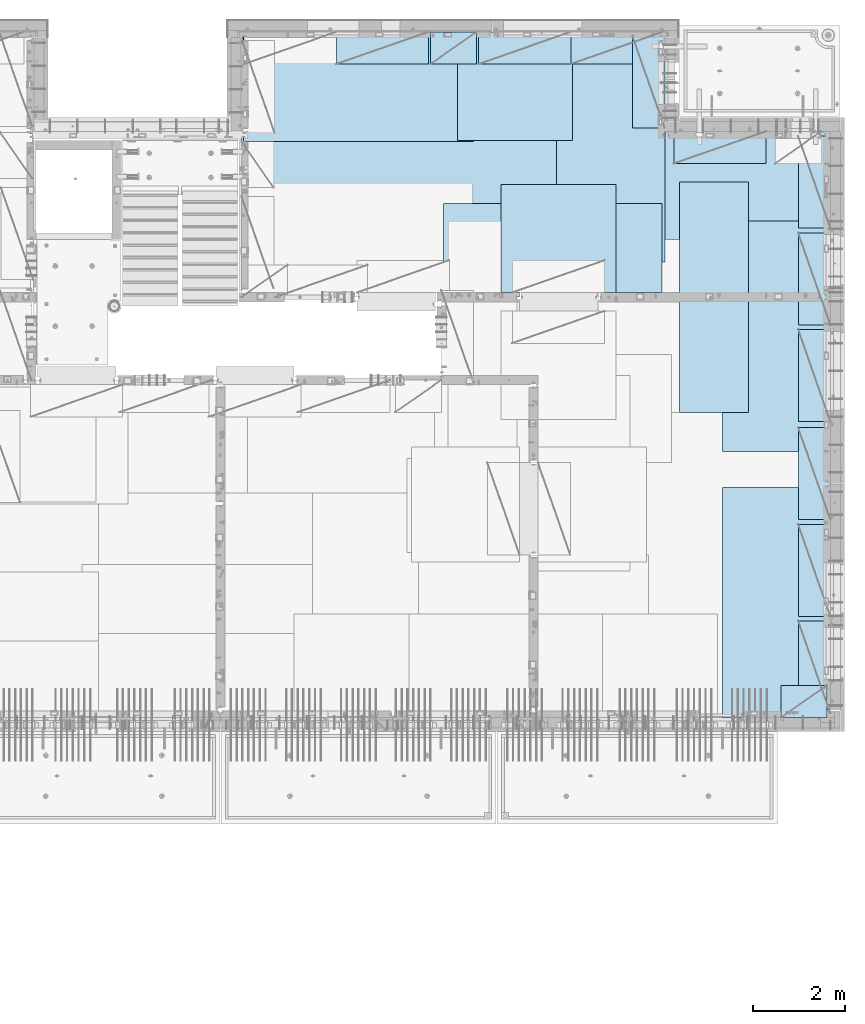
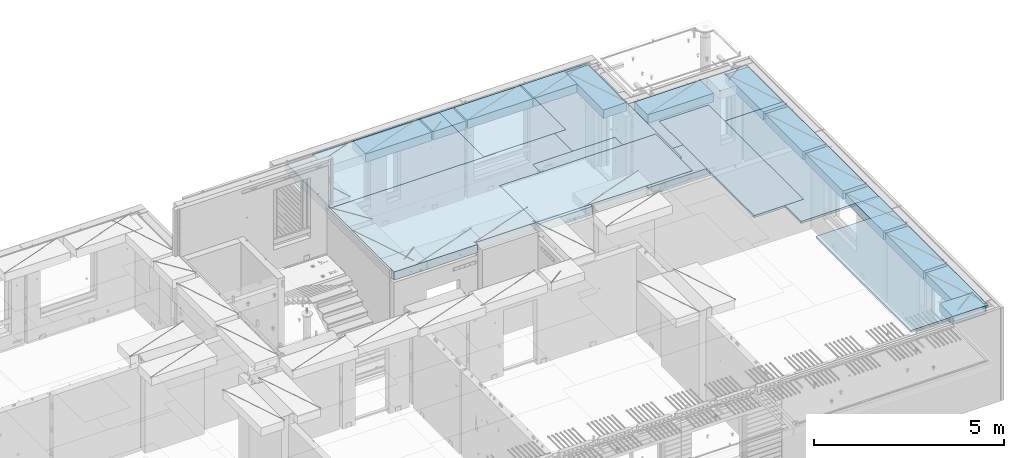
# One storey, part 202 of 341: 22 plates, 1 slab, 22 elements without a shape of their own.
"""IFC2X3 building model written with IfcOpenShell, lengths in millimetres."""

from ifc_helpers import new_model, si_unit, frame, origin_with_axes, place, context, subcontext, project, spatial, faceted_brep, material, type_object, element, aggregate, save


model = new_model("IFC2X3")

# Units and contexts
model_context = context("Model", 3, precision=1e-05, world=origin_with_axes())
body_context = subcontext(model_context, "Body", "Model", "MODEL_VIEW")
ifc_project = project(units=[si_unit("LENGTHUNIT", "METRE", prefix="MILLI"), si_unit("AREAUNIT", "SQUARE_METRE"), si_unit("VOLUMEUNIT", "CUBIC_METRE"), si_unit("MASSUNIT", "GRAM", prefix="KILO"), si_unit("TIMEUNIT", "SECOND"), si_unit("PLANEANGLEUNIT", "RADIAN"), si_unit("SOLIDANGLEUNIT", "STERADIAN"), si_unit("THERMODYNAMICTEMPERATUREUNIT", "DEGREE_CELSIUS"), si_unit("LUMINOUSINTENSITYUNIT", "LUMEN")], contexts=[model_context])

# Site, building, storey
site_placement = place(None, origin_with_axes())
site = spatial("IfcSite", under=ifc_project, at=site_placement, CompositionType="ELEMENT")
building_placement = place(site_placement, origin_with_axes())
building = spatial("IfcBuilding", under=site, at=building_placement, CompositionType="ELEMENT")
storey_placement = place(building_placement, origin_with_axes())
storey = spatial("IfcBuildingStorey", under=building, at=storey_placement, Name="5", CompositionType="ELEMENT", Elevation=0.0)

# Assembly, slab
assembly_1_placement = place(storey_placement, origin_with_axes())
assembly_1 = element("IfcElementAssembly", 1, at=assembly_1_placement, inside=storey, AssemblyPlace="NOTDEFINED", PredefinedType="REINFORCEMENT_UNIT")
ifc_material_1 = material(Name="CONCRETE/C30/37")
slab_type = type_object("IfcSlabType", PredefinedType="NOTDEFINED")
slab_placement = place(assembly_1_placement, frame((22310.0, 16980.0, 96595.0), z_axis=(0.0, 1.0, 0.0), x_axis=(1.0, 0.0, 0.0)))
slab = element("IfcSlab", 2, at=slab_placement, type_object=slab_type, material=ifc_material_1, PredefinedType="FLOOR", context=body_context, shape_type="Brep", body=[
    faceted_brep([(4369.99914550782, -135.0, 99.9999987875526), (4369.99914550782, 135.0, 99.9999987875526), (4369.99914550782, 135.0, 0.0), (4369.99914550782, -135.0, 0.0), (4169.99914550781, -135.0, 99.9997253417969), (4169.99914550781, 135.0, 99.9997253417969), (2489.99914550781, -135.0, 0.0), (2489.99914550781, 135.0, 0.0), (2489.99914550781, 135.0, 99.9997253417969), (2489.99914550781, -135.0, 99.9997253417969), (1.81898940354586e-12, -135.0, 1.81898940354586e-12), (1.81898940354586e-12, 135.0, 1.81898940354586e-12), (-39.9985427856445, -135.0, -0.0037095642182976), (-39.9985427856445, 135.0, -0.0037095642182976), (-40.0, -135.0, 3600.00048828125), (-40.0, 135.0, 3600.00048828125), (-20.0, -135.0, 3600.0), (-20.0, 135.0, 3600.0), (-20.0, -135.0, 5760.0), (-20.0, 135.0, 5760.0), (9149.9990234375, -135.0, 5760.0), (9149.9990234375, 135.0, 5760.0), (9149.9990234375, -135.0, 3600.00073242188), (9149.9990234375, 135.0, 3600.00073242188), (12750.0, -135.0, 3599.9951171875), (12750.0, 135.0, 3599.9951171875), (12750.0, -135.0, 0.0), (12750.0, 135.0, 0.0), (7685.0006429507, -135.0, 0.0), (7685.0006429507, 135.0, 0.0), (7685.0006429507, -135.0, 99.9996630941932), (7685.0006429507, 135.0, 99.9996630941932), (5999.99954431789, -135.0, 99.9996630941932), (5999.99954431789, 135.0, 99.9996630941932), (5999.99954431789, -135.0, 0.0), (5999.99954431789, 135.0, 0.0), (2730.00000000001, 135.0, 99.9997253417969), (2730.00000000001, -135.0, 99.9997253417969)], [[[0, 1, 2, 3]], [[4, 5, 1, 0]], [[6, 7, 8, 9]], [[10, 11, 7, 6]], [[10, 12, 13, 11]], [[12, 14, 15, 13]], [[14, 16, 17, 15]], [[16, 18, 19, 17]], [[18, 20, 21, 19]], [[20, 22, 23, 21]], [[22, 24, 25, 23]], [[24, 26, 27, 25]], [[27, 26, 28, 29]], [[30, 31, 29, 28]], [[32, 33, 31, 30]], [[34, 35, 33, 32]], [[35, 34, 3, 2]], [[36, 8, 7, 11, 13, 15, 17, 19, 21, 23, 25, 27, 29, 31, 33, 35, 2, 1, 5]], [[37, 9, 8, 36, 5, 4]], [[34, 32, 30, 28, 26, 24, 22, 20, 18, 16, 14, 12, 10, 6, 9, 37, 4, 0, 3]]]),
])

# Assembly, plate
assembly_2_placement = place(storey_placement, origin_with_axes())
assembly_2 = element("IfcElementAssembly", 3, at=assembly_2_placement, inside=storey, Name="Steel Assembly", AssemblyPlace="NOTDEFINED", PredefinedType="NOTDEFINED")
ifc_material_2 = material()
plate_type_1 = type_object("IfcPlateType", PredefinedType="NOTDEFINED")
plate_1_placement = place(assembly_2_placement, frame((26960.07, 22728.45, 96695.1), z_axis=(1.0, 0.0, 0.0), x_axis=(0.0, -1.0, 0.0)))
plate_1 = element("IfcPlate", 4, at=plate_1_placement, type_object=plate_type_1, material=ifc_material_2, Name="1/2", context=body_context, shape_type="Brep", body=[
    faceted_brep([(0.0, -35.0, 0.0), (0.0, -35.0, 2500.0), (0.0, 35.0, 2500.0), (0.0, 35.0, 0.0), (2349.99951171875, -35.0, 2500.0), (2349.99951171875, 35.0, 2500.0), (2350.0, -35.0, 0.0), (2350.0, 35.0, 0.0)], [[[0, 1, 2, 3]], [[1, 4, 5, 2]], [[4, 6, 7, 5]], [[6, 0, 3, 7]], [[5, 7, 3, 2]], [[6, 4, 1, 0]]]),
])
aggregate(assembly_2, [plate_1])

assembly_3_placement = place(storey_placement, origin_with_axes())
assembly_3 = element("IfcElementAssembly", 5, at=assembly_3_placement, inside=storey, Name="Steel Assembly", AssemblyPlace="NOTDEFINED", PredefinedType="NOTDEFINED")
plate_2_placement = place(assembly_3_placement, frame((22309.9998779297, 22710.0009765625, 96695.1), z_axis=(1.0, 0.0, 0.0), x_axis=(0.0, -1.0, 0.0)))
plate_2 = element("IfcPlate", 6, at=plate_2_placement, type_object=plate_type_1, material=ifc_material_2, context=body_context, shape_type="Brep", body=[
    faceted_brep([(0.0, -35.0, 0.0), (0.0, -35.0, 5000.0), (0.0, 35.0, 5000.0), (0.0, 35.0, 0.0), (2349.99951171875, -35.0, 5000.0), (2349.99951171875, 35.0, 5000.0), (2350.0, -35.0, 0.0), (2350.0, 35.0, 0.0)], [[[0, 1, 2, 3]], [[1, 4, 5, 2]], [[4, 6, 7, 5]], [[6, 0, 3, 7]], [[5, 7, 3, 2]], [[6, 4, 1, 0]]]),
])
aggregate(assembly_3, [plate_2])

assembly_4_placement = place(storey_placement, origin_with_axes())
assembly_4 = element("IfcElementAssembly", 7, at=assembly_4_placement, inside=storey, Name="Steel Assembly", AssemblyPlace="NOTDEFINED", PredefinedType="NOTDEFINED")
plate_3_placement = place(assembly_4_placement, frame((27902.5, 19430.0, 96695.1), z_axis=(1.0, 0.0, 0.0), x_axis=(0.0, -1.0, 0.0)))
plate_3 = element("IfcPlate", 8, at=plate_3_placement, type_object=plate_type_1, material=ifc_material_2, Name="1/2", context=body_context, shape_type="Brep", body=[
    faceted_brep([(0.0, -35.0, 0.0), (0.0, -35.0, 2500.0), (0.0, 35.0, 2500.0), (0.0, 35.0, 0.0), (2349.99951171875, -35.0, 2500.0), (2349.99951171875, 35.0, 2500.0), (2350.0, -35.0, 0.0), (2350.0, 35.0, 0.0)], [[[0, 1, 2, 3]], [[1, 4, 5, 2]], [[4, 6, 7, 5]], [[6, 0, 3, 7]], [[5, 7, 3, 2]], [[6, 4, 1, 0]]]),
])
aggregate(assembly_4, [plate_3])

assembly_5_placement = place(storey_placement, origin_with_axes())
assembly_5 = element("IfcElementAssembly", 9, at=assembly_5_placement, inside=storey, Name="Steel Assembly", AssemblyPlace="NOTDEFINED", PredefinedType="NOTDEFINED")
plate_4_placement = place(assembly_5_placement, frame((31460.0, 22740.0, 96695.1), z_axis=(0.0, -1.0, 0.0), x_axis=(-1.0, 3.00000001838171e-08, 0.0)))
plate_4 = element("IfcPlate", 10, at=plate_4_placement, type_object=plate_type_1, material=ifc_material_2, context=body_context, shape_type="Brep", body=[
    faceted_brep([(0.0, -35.0, 0.0), (0.0, -35.0, 5000.0), (0.0, 35.0, 5000.0), (0.0, 35.0, 0.0), (2349.99951171875, -35.0, 5000.0), (2349.99951171875, 35.0, 5000.0), (2350.0, -35.0, 0.0), (2350.0, 35.0, 0.0)], [[[0, 1, 2, 3]], [[1, 4, 5, 2]], [[4, 6, 7, 5]], [[6, 0, 3, 7]], [[5, 7, 3, 2]], [[6, 4, 1, 0]]]),
])
aggregate(assembly_5, [plate_4])

assembly_6_placement = place(storey_placement, origin_with_axes())
assembly_6 = element("IfcElementAssembly", 11, at=assembly_6_placement, inside=storey, Name="Steel Assembly", AssemblyPlace="NOTDEFINED", PredefinedType="NOTDEFINED")
plate_5_placement = place(assembly_6_placement, frame((35060.0, 12850.0, 96695.1), z_axis=(0.0, -1.0, 0.0), x_axis=(-1.0, 3.00000001838171e-08, 0.0)))
plate_5 = element("IfcPlate", 12, at=plate_5_placement, type_object=plate_type_1, material=ifc_material_2, context=body_context, shape_type="Brep", body=[
    faceted_brep([(0.0, -35.0, 0.0), (0.0, -35.0, 5000.0), (0.0, 35.0, 5000.0), (0.0, 35.0, 0.0), (2349.99951171875, -35.0, 5000.0), (2349.99951171875, 35.0, 5000.0), (2350.0, -35.0, 0.0), (2350.0, 35.0, 0.0)], [[[0, 1, 2, 3]], [[1, 4, 5, 2]], [[4, 6, 7, 5]], [[6, 0, 3, 7]], [[5, 7, 3, 2]], [[6, 4, 1, 0]]]),
])
aggregate(assembly_6, [plate_5])

assembly_7_placement = place(storey_placement, origin_with_axes())
assembly_7 = element("IfcElementAssembly", 13, at=assembly_7_placement, inside=storey, Name="Steel Assembly", AssemblyPlace="NOTDEFINED", PredefinedType="NOTDEFINED")
plate_6_placement = place(assembly_7_placement, frame((35060.0, 18630.0, 96695.1), z_axis=(0.0, -1.0, 0.0), x_axis=(-1.0, 3.00000001838171e-08, 0.0)))
plate_6 = element("IfcPlate", 14, at=plate_6_placement, type_object=plate_type_1, material=ifc_material_2, context=body_context, shape_type="Brep", body=[
    faceted_brep([(0.0, -35.0, 0.0), (0.0, -35.0, 5000.0), (0.0, 35.0, 5000.0), (0.0, 35.0, 0.0), (2349.99951171875, -35.0, 5000.0), (2349.99951171875, 35.0, 5000.0), (2350.0, -35.0, 0.0), (2350.0, 35.0, 0.0)], [[[0, 1, 2, 3]], [[1, 4, 5, 2]], [[4, 6, 7, 5]], [[6, 0, 3, 7]], [[5, 7, 3, 2]], [[6, 4, 1, 0]]]),
])
aggregate(assembly_7, [plate_6])

assembly_8_placement = place(storey_placement, origin_with_axes())
assembly_8 = element("IfcElementAssembly", 15, at=assembly_8_placement, inside=storey, Name="Steel Assembly", AssemblyPlace="NOTDEFINED", PredefinedType="NOTDEFINED")
plate_7_placement = place(assembly_8_placement, frame((30060.0, 20580.0, 96695.1), z_axis=(1.0, 0.0, 0.0), x_axis=(0.0, -1.0, 0.0)))
plate_7 = element("IfcPlate", 16, at=plate_7_placement, type_object=plate_type_1, material=ifc_material_2, context=body_context, shape_type="Brep", body=[
    faceted_brep([(0.0, -35.0, 0.0), (0.0, -35.0, 5000.0), (0.0, 35.0, 5000.0), (0.0, 35.0, 0.0), (2349.99951171875, -35.0, 5000.0), (2349.99951171875, 35.0, 5000.0), (2350.0, -35.0, 0.0), (2350.0, 35.0, 0.0)], [[[0, 1, 2, 3]], [[1, 4, 5, 2]], [[4, 6, 7, 5]], [[6, 0, 3, 7]], [[5, 7, 3, 2]], [[6, 4, 1, 0]]]),
])
aggregate(assembly_8, [plate_7])

assembly_9_placement = place(storey_placement, origin_with_axes())
assembly_9 = element("IfcElementAssembly", 17, at=assembly_9_placement, inside=storey, Name="Steel Assembly", AssemblyPlace="NOTDEFINED", PredefinedType="NOTDEFINED")
plate_type_2 = type_object("IfcPlateType", PredefinedType="NOTDEFINED")
plate_8_placement = place(assembly_9_placement, frame((33275.0000122641, 19480.0, 96695.1000003815), z_axis=(0.0, -1.0, 0.0), x_axis=(-1.0, 3.00000001838171e-08, 0.0)))
plate_8 = element("IfcPlate", 18, at=plate_8_placement, type_object=plate_type_2, material=ifc_material_2, context=body_context, shape_type="Brep", body=[
    faceted_brep([(0.0, -35.0, 0.0), (0.0, -35.0, 5000.0), (0.0, 35.0, 5000.0), (0.0, 35.0, 0.0), (1499.99951171875, -35.0, 5000.0), (1499.99951171875, 35.0, 5000.0), (1500.0, -35.0, 0.0), (1500.0, 35.0, 0.0)], [[[0, 1, 2, 3]], [[1, 4, 5, 2]], [[4, 6, 7, 5]], [[6, 0, 3, 7]], [[5, 7, 3, 2]], [[6, 4, 1, 0]]]),
])
aggregate(assembly_9, [plate_8])

assembly_10_placement = place(storey_placement, origin_with_axes())
assembly_10 = element("IfcElementAssembly", 19, at=assembly_10_placement, inside=storey, Name="Steel Assembly", AssemblyPlace="NOTDEFINED", PredefinedType="NOTDEFINED")
plate_type_3 = type_object("IfcPlateType", PredefinedType="NOTDEFINED")
plate_9_placement = place(assembly_10_placement, frame((31420.0, 22740.0001220703, 96595.3), z_axis=(0.0, -1.0, 0.0), x_axis=(-1.0, 3.00000001838171e-08, 0.0)))
plate_9 = element("IfcPlate", 20, at=plate_9_placement, type_object=plate_type_3, material=ifc_material_2, Name="RE1", context=body_context, shape_type="Brep", body=[
    faceted_brep([(1.81898940354586e-12, -135.0, 1.81898940354586e-12), (0.0, -135.0, 699.999999999996), (0.0, 135.0, 699.999999999996), (1.81898940354586e-12, 135.0, 1.81898940354586e-12), (1999.99951171875, -135.0, 699.999999999993), (1999.99951171875, 135.0, 699.999999999993), (2000.0, -135.0, -3.63797880709171e-12), (2000.0, 135.0, -3.63797880709171e-12)], [[[0, 1, 2, 3]], [[1, 4, 5, 2]], [[4, 6, 7, 5]], [[6, 0, 3, 7]], [[5, 7, 3, 2]], [[6, 4, 1, 0]]]),
])
aggregate(assembly_10, [plate_9])

assembly_11_placement = place(storey_placement, origin_with_axes())
assembly_11 = element("IfcElementAssembly", 21, at=assembly_11_placement, inside=storey, Name="Steel Assembly", AssemblyPlace="NOTDEFINED", PredefinedType="NOTDEFINED")
plate_10_placement = place(assembly_11_placement, frame((33985.0, 7849.99999992931, 96595.3), z_axis=(0.0, 1.0, 0.0), x_axis=(1.0, 0.0, 0.0)))
plate_10 = element("IfcPlate", 22, at=plate_10_placement, type_object=plate_type_3, material=ifc_material_2, Name="RE1_1/2", context=body_context, shape_type="Brep", body=[
    faceted_brep([(1.81898940354586e-12, -135.0, 1.81898940354586e-12), (0.0, -135.0, 699.999999999996), (0.0, 135.0, 699.999999999996), (1.81898940354586e-12, 135.0, 1.81898940354586e-12), (999.99951171875, -135.0, 700.0), (999.99951171875, 135.0, 700.0), (1000.0, -135.0, 0.0), (1000.0, 135.0, 0.0)], [[[0, 1, 2, 3]], [[1, 4, 5, 2]], [[4, 6, 7, 5]], [[6, 0, 3, 7]], [[5, 7, 3, 2]], [[6, 4, 1, 0]]]),
])
aggregate(assembly_11, [plate_10])

assembly_12_placement = place(storey_placement, origin_with_axes())
assembly_12 = element("IfcElementAssembly", 23, at=assembly_12_placement, inside=storey, Name="Steel Assembly", AssemblyPlace="NOTDEFINED", PredefinedType="NOTDEFINED")
plate_11_placement = place(assembly_12_placement, frame((35060.0001220703, 14280.0, 96595.3), z_axis=(-1.0, 3.00000001838171e-08, 0.0), x_axis=(0.0, 1.0, 0.0)))
plate_11 = element("IfcPlate", 24, at=plate_11_placement, type_object=plate_type_3, material=ifc_material_2, Name="RE1", context=body_context, shape_type="Brep", body=[
    faceted_brep([(1.81898940354586e-12, -135.0, 1.81898940354586e-12), (0.0, -135.0, 699.999999999996), (0.0, 135.0, 699.999999999996), (1.81898940354586e-12, 135.0, 1.81898940354586e-12), (1999.99951171875, -135.0, 699.999999999993), (1999.99951171875, 135.0, 699.999999999993), (2000.0, -135.0, -3.63797880709171e-12), (2000.0, 135.0, -3.63797880709171e-12)], [[[0, 1, 2, 3]], [[1, 4, 5, 2]], [[4, 6, 7, 5]], [[6, 0, 3, 7]], [[5, 7, 3, 2]], [[6, 4, 1, 0]]]),
])
aggregate(assembly_12, [plate_11])

assembly_13_placement = place(storey_placement, origin_with_axes())
assembly_13 = element("IfcElementAssembly", 25, at=assembly_13_placement, inside=storey, Name="Steel Assembly", AssemblyPlace="NOTDEFINED", PredefinedType="NOTDEFINED")
plate_12_placement = place(assembly_13_placement, frame((35060.0001220703, 16380.0, 96595.3), z_axis=(-1.0, 3.00000001838171e-08, 0.0), x_axis=(0.0, 1.0, 0.0)))
plate_12 = element("IfcPlate", 26, at=plate_12_placement, type_object=plate_type_3, material=ifc_material_2, Name="RE1", context=body_context, shape_type="Brep", body=[
    faceted_brep([(1.81898940354586e-12, -135.0, 1.81898940354586e-12), (0.0, -135.0, 699.999999999996), (0.0, 135.0, 699.999999999996), (1.81898940354586e-12, 135.0, 1.81898940354586e-12), (1999.99951171875, -135.0, 699.999999999993), (1999.99951171875, 135.0, 699.999999999993), (2000.0, -135.0, -3.63797880709171e-12), (2000.0, 135.0, -3.63797880709171e-12)], [[[0, 1, 2, 3]], [[1, 4, 5, 2]], [[4, 6, 7, 5]], [[6, 0, 3, 7]], [[5, 7, 3, 2]], [[6, 4, 1, 0]]]),
])
aggregate(assembly_13, [plate_12])

assembly_14_placement = place(storey_placement, origin_with_axes())
assembly_14 = element("IfcElementAssembly", 27, at=assembly_14_placement, inside=storey, Name="Steel Assembly", AssemblyPlace="NOTDEFINED", PredefinedType="NOTDEFINED")
plate_13_placement = place(assembly_14_placement, frame((35060.0001220703, 18480.0, 96595.3), z_axis=(-1.0, 3.00000001838171e-08, 0.0), x_axis=(0.0, 1.0, 0.0)))
plate_13 = element("IfcPlate", 28, at=plate_13_placement, type_object=plate_type_3, material=ifc_material_2, Name="RE1", context=body_context, shape_type="Brep", body=[
    faceted_brep([(1.81898940354586e-12, -135.0, 1.81898940354586e-12), (0.0, -135.0, 699.999999999996), (0.0, 135.0, 699.999999999996), (1.81898940354586e-12, 135.0, 1.81898940354586e-12), (1999.99951171875, -135.0, 699.999999999993), (1999.99951171875, 135.0, 699.999999999993), (2000.0, -135.0, -3.63797880709171e-12), (2000.0, 135.0, -3.63797880709171e-12)], [[[0, 1, 2, 3]], [[1, 4, 5, 2]], [[4, 6, 7, 5]], [[6, 0, 3, 7]], [[5, 7, 3, 2]], [[6, 4, 1, 0]]]),
])
aggregate(assembly_14, [plate_13])

assembly_15_placement = place(storey_placement, origin_with_axes())
assembly_15 = element("IfcElementAssembly", 29, at=assembly_15_placement, inside=storey, Name="Steel Assembly", AssemblyPlace="NOTDEFINED", PredefinedType="NOTDEFINED")
plate_14_placement = place(assembly_15_placement, frame((35060.0001220703, 12150.0, 96595.3), z_axis=(-1.0, 3.00000001838171e-08, 0.0), x_axis=(0.0, 1.0, 0.0)))
plate_14 = element("IfcPlate", 30, at=plate_14_placement, type_object=plate_type_3, material=ifc_material_2, Name="RE1", context=body_context, shape_type="Brep", body=[
    faceted_brep([(1.81898940354586e-12, -135.0, 1.81898940354586e-12), (0.0, -135.0, 699.999999999996), (0.0, 135.0, 699.999999999996), (1.81898940354586e-12, 135.0, 1.81898940354586e-12), (1999.99951171875, -135.0, 699.999999999993), (1999.99951171875, 135.0, 699.999999999993), (2000.0, -135.0, -3.63797880709171e-12), (2000.0, 135.0, -3.63797880709171e-12)], [[[0, 1, 2, 3]], [[1, 4, 5, 2]], [[4, 6, 7, 5]], [[6, 0, 3, 7]], [[5, 7, 3, 2]], [[6, 4, 1, 0]]]),
])
aggregate(assembly_15, [plate_14])

assembly_16_placement = place(storey_placement, origin_with_axes())
assembly_16 = element("IfcElementAssembly", 31, at=assembly_16_placement, inside=storey, Name="Steel Assembly", AssemblyPlace="NOTDEFINED", PredefinedType="NOTDEFINED")
plate_15_placement = place(assembly_16_placement, frame((35060.0001220703, 10050.0, 96595.3), z_axis=(-1.0, 3.00000001838171e-08, 0.0), x_axis=(0.0, 1.0, 0.0)))
plate_15 = element("IfcPlate", 32, at=plate_15_placement, type_object=plate_type_3, material=ifc_material_2, Name="RE1", context=body_context, shape_type="Brep", body=[
    faceted_brep([(1.81898940354586e-12, -135.0, 1.81898940354586e-12), (0.0, -135.0, 699.999999999996), (0.0, 135.0, 699.999999999996), (1.81898940354586e-12, 135.0, 1.81898940354586e-12), (1999.99951171875, -135.0, 699.999999999993), (1999.99951171875, 135.0, 699.999999999993), (2000.0, -135.0, -3.63797880709171e-12), (2000.0, 135.0, -3.63797880709171e-12)], [[[0, 1, 2, 3]], [[1, 4, 5, 2]], [[4, 6, 7, 5]], [[6, 0, 3, 7]], [[5, 7, 3, 2]], [[6, 4, 1, 0]]]),
])
aggregate(assembly_16, [plate_15])

assembly_17_placement = place(storey_placement, origin_with_axes())
assembly_17 = element("IfcElementAssembly", 33, at=assembly_17_placement, inside=storey, Name="Steel Assembly", AssemblyPlace="NOTDEFINED", PredefinedType="NOTDEFINED")
plate_16_placement = place(assembly_17_placement, frame((35060.0001220703, 7950.0, 96595.3), z_axis=(-1.0, 3.00000001838171e-08, 0.0), x_axis=(0.0, 1.0, 0.0)))
plate_16 = element("IfcPlate", 34, at=plate_16_placement, type_object=plate_type_3, material=ifc_material_2, Name="RE1", context=body_context, shape_type="Brep", body=[
    faceted_brep([(1.81898940354586e-12, -135.0, 1.81898940354586e-12), (0.0, -135.0, 699.999999999996), (0.0, 135.0, 699.999999999996), (1.81898940354586e-12, 135.0, 1.81898940354586e-12), (1999.99951171875, -135.0, 699.999999999993), (1999.99951171875, 135.0, 699.999999999993), (2000.0, -135.0, -3.63797880709171e-12), (2000.0, 135.0, -3.63797880709171e-12)], [[[0, 1, 2, 3]], [[1, 4, 5, 2]], [[4, 6, 7, 5]], [[6, 0, 3, 7]], [[5, 7, 3, 2]], [[6, 4, 1, 0]]]),
])
aggregate(assembly_17, [plate_16])

assembly_18_placement = place(storey_placement, origin_with_axes())
assembly_18 = element("IfcElementAssembly", 35, at=assembly_18_placement, inside=storey, Name="Steel Assembly", AssemblyPlace="NOTDEFINED", PredefinedType="NOTDEFINED")
plate_17_placement = place(assembly_18_placement, frame((33660.0, 20580.0001220703, 96595.3), z_axis=(0.0, -1.0, 0.0), x_axis=(-1.0, 3.00000001838171e-08, 0.0)))
plate_17 = element("IfcPlate", 36, at=plate_17_placement, type_object=plate_type_3, material=ifc_material_2, Name="RE1", context=body_context, shape_type="Brep", body=[
    faceted_brep([(1.81898940354586e-12, -135.0, 1.81898940354586e-12), (0.0, -135.0, 699.999999999996), (0.0, 135.0, 699.999999999996), (1.81898940354586e-12, 135.0, 1.81898940354586e-12), (1999.99951171875, -135.0, 699.999999999993), (1999.99951171875, 135.0, 699.999999999993), (2000.0, -135.0, -3.63797880709171e-12), (2000.0, 135.0, -3.63797880709171e-12)], [[[0, 1, 2, 3]], [[1, 4, 5, 2]], [[4, 6, 7, 5]], [[6, 0, 3, 7]], [[5, 7, 3, 2]], [[6, 4, 1, 0]]]),
])
aggregate(assembly_18, [plate_17])

assembly_19_placement = place(storey_placement, origin_with_axes())
assembly_19 = element("IfcElementAssembly", 37, at=assembly_19_placement, inside=storey, Name="Steel Assembly", AssemblyPlace="NOTDEFINED", PredefinedType="NOTDEFINED")
plate_18_placement = place(assembly_19_placement, frame((31460.0001220703, 20660.0, 96595.3), z_axis=(-1.0, 3.00000001838171e-08, 0.0), x_axis=(0.0, 1.0, 0.0)))
plate_18 = element("IfcPlate", 38, at=plate_18_placement, type_object=plate_type_3, material=ifc_material_2, Name="RE1", context=body_context, shape_type="Brep", body=[
    faceted_brep([(1.81898940354586e-12, -135.0, 1.81898940354586e-12), (0.0, -135.0, 699.999999999996), (0.0, 135.0, 699.999999999996), (1.81898940354586e-12, 135.0, 1.81898940354586e-12), (1999.99951171875, -135.0, 699.999999999993), (1999.99951171875, 135.0, 699.999999999993), (2000.0, -135.0, -3.63797880709171e-12), (2000.0, 135.0, -3.63797880709171e-12)], [[[0, 1, 2, 3]], [[1, 4, 5, 2]], [[4, 6, 7, 5]], [[6, 0, 3, 7]], [[5, 7, 3, 2]], [[6, 4, 1, 0]]]),
])
aggregate(assembly_19, [plate_18])

assembly_20_placement = place(storey_placement, origin_with_axes())
assembly_20 = element("IfcElementAssembly", 39, at=assembly_20_placement, inside=storey, Name="Steel Assembly", AssemblyPlace="NOTDEFINED", PredefinedType="NOTDEFINED")
plate_19_placement = place(assembly_20_placement, frame((26330.0, 22740.0001220703, 96595.3), z_axis=(0.0, -1.0, 0.0), x_axis=(-1.0, 3.00000001838171e-08, 0.0)))
plate_19 = element("IfcPlate", 40, at=plate_19_placement, type_object=plate_type_3, material=ifc_material_2, Name="RE1", context=body_context, shape_type="Brep", body=[
    faceted_brep([(1.81898940354586e-12, -135.0, 1.81898940354586e-12), (0.0, -135.0, 699.999999999996), (0.0, 135.0, 699.999999999996), (1.81898940354586e-12, 135.0, 1.81898940354586e-12), (1999.99951171875, -135.0, 699.999999999993), (1999.99951171875, 135.0, 699.999999999993), (2000.0, -135.0, -3.63797880709171e-12), (2000.0, 135.0, -3.63797880709171e-12)], [[[0, 1, 2, 3]], [[1, 4, 5, 2]], [[4, 6, 7, 5]], [[6, 0, 3, 7]], [[5, 7, 3, 2]], [[6, 4, 1, 0]]]),
])
aggregate(assembly_20, [plate_19])

assembly_21_placement = place(storey_placement, origin_with_axes())
assembly_21 = element("IfcElementAssembly", 41, at=assembly_21_placement, inside=storey, Name="Steel Assembly", AssemblyPlace="NOTDEFINED", PredefinedType="NOTDEFINED")
plate_20_placement = place(assembly_21_placement, frame((29420.0, 22740.0001220703, 96595.3), z_axis=(0.0, -1.0, 0.0), x_axis=(-1.0, 3.00000001838171e-08, 0.0)))
plate_20 = element("IfcPlate", 42, at=plate_20_placement, type_object=plate_type_3, material=ifc_material_2, Name="RE1", context=body_context, shape_type="Brep", body=[
    faceted_brep([(1.81898940354586e-12, -135.0, 1.81898940354586e-12), (0.0, -135.0, 699.999999999996), (0.0, 135.0, 699.999999999996), (1.81898940354586e-12, 135.0, 1.81898940354586e-12), (1999.99951171875, -135.0, 699.999999999993), (1999.99951171875, 135.0, 699.999999999993), (2000.0, -135.0, -3.63797880709171e-12), (2000.0, 135.0, -3.63797880709171e-12)], [[[0, 1, 2, 3]], [[1, 4, 5, 2]], [[4, 6, 7, 5]], [[6, 0, 3, 7]], [[5, 7, 3, 2]], [[6, 4, 1, 0]]]),
])
aggregate(assembly_21, [plate_20])

assembly_22_placement = place(storey_placement, origin_with_axes())
assembly_22 = element("IfcElementAssembly", 43, at=assembly_22_placement, inside=storey, Name="Steel Assembly", AssemblyPlace="NOTDEFINED", PredefinedType="NOTDEFINED")
plate_21_placement = place(assembly_22_placement, frame((27375.0, 22740.0000000707, 96595.3), z_axis=(0.0, -1.0, 0.0), x_axis=(-1.0, 3.00000001838171e-08, 0.0)))
plate_21 = element("IfcPlate", 44, at=plate_21_placement, type_object=plate_type_3, material=ifc_material_2, Name="RE1_1/2", context=body_context, shape_type="Brep", body=[
    faceted_brep([(1.81898940354586e-12, -135.0, 1.81898940354586e-12), (0.0, -135.0, 699.999999999996), (0.0, 135.0, 699.999999999996), (1.81898940354586e-12, 135.0, 1.81898940354586e-12), (999.99951171875, -135.0, 700.0), (999.99951171875, 135.0, 700.0), (1000.0, -135.0, 0.0), (1000.0, 135.0, 0.0)], [[[0, 1, 2, 3]], [[1, 4, 5, 2]], [[4, 6, 7, 5]], [[6, 0, 3, 7]], [[5, 7, 3, 2]], [[6, 4, 1, 0]]]),
])
aggregate(assembly_22, [plate_21])

# Plate
plate_type_4 = type_object("IfcPlateType", PredefinedType="NOTDEFINED")
plate_22_placement = place(assembly_1_placement, frame((31402.0004441066, 19019.9993561238, 96725.45), z_axis=(0.0, -1.0, 0.0), x_axis=(-1.0, 3.00000001838171e-08, 0.0)))
plate_22 = element("IfcPlate", 45, at=plate_22_placement, type_object=plate_type_4, material=ifc_material_2, context=body_context, shape_type="Brep", body=[
    faceted_brep([(0.0, -5.0, 0.0), (0.0, -5.0, 1939.99963378906), (0.0, 5.0, 1939.99963378906), (0.0, 5.0, 0.0), (4742.00048828125, -5.0, 1939.99963378906), (4742.00048828125, 5.0, 1939.99963378906), (4742.00048828125, -5.0, 0.0), (4742.00048828125, 5.0, 0.0), (92.0009613037109, -5.0, 0.0), (92.0009613037109, 5.0, 0.0)], [[[0, 1, 2, 3]], [[1, 4, 5, 2]], [[4, 6, 7, 5]], [[6, 8, 9, 7]], [[8, 0, 3, 9]], [[5, 7, 9, 3, 2]], [[8, 6, 4, 1, 0]]]),
])

aggregate(assembly_1, [plate_22, slab])

save(model, "model.ifc")
